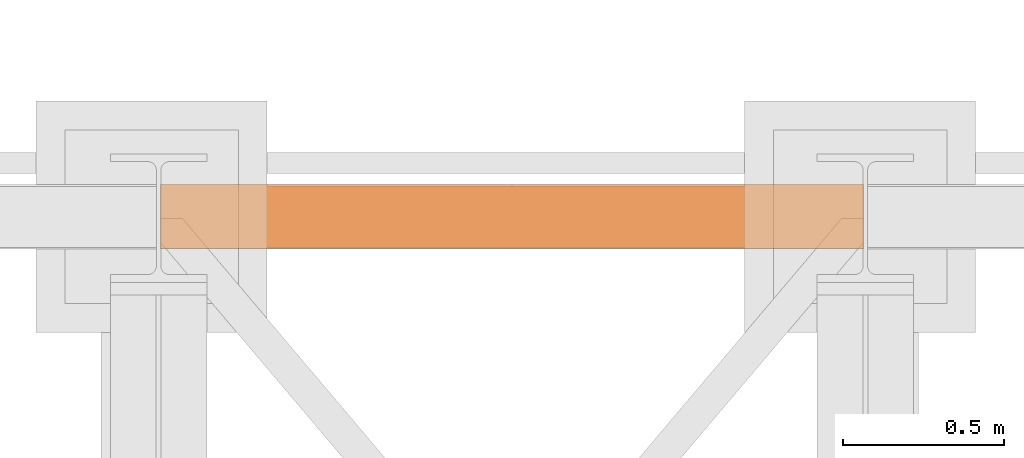
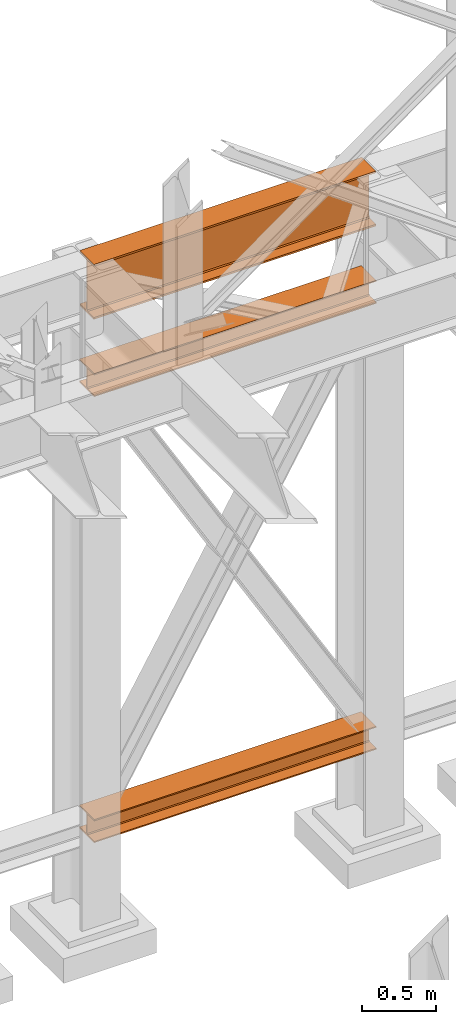
# One storey, part 139 of 208: 3 proxies.
"""IFC2X3 building model written with IfcOpenShell, lengths in millimetres."""

from ifc_helpers import new_model, entity, si_unit, converted_unit, frame, origin, origin_with_axes, place, context, subcontext, project, spatial, faceted_brep, element, save


model = new_model("IFC2X3")

# Units and contexts
model_context = context("Model", 3, precision=1e-05, world=origin())
plan_context = context("Plan", 3, precision=1e-05, world=origin())
body_context = subcontext(model_context, "Body", "Model", "MODEL_VIEW")
ifc_project = project(units=[si_unit("LENGTHUNIT", "METRE", prefix="MILLI"), converted_unit("PLANEANGLEUNIT", "DEGREE", entity("IfcPlaneAngleMeasure", 0.0174532925199433), si_unit("PLANEANGLEUNIT", "RADIAN"), dimensions=[0, 0, 0, 0, 0, 0, 0]), si_unit("AREAUNIT", "SQUARE_METRE"), si_unit("VOLUMEUNIT", "CUBIC_METRE")], contexts=[model_context, plan_context])

# Building, storey
building_placement = place(None, origin())
building = spatial("IfcBuilding", under=ifc_project, at=building_placement, CompositionType="COMPLEX")
storey_placement = place(building_placement, origin_with_axes())
storey = spatial("IfcBuildingStorey", under=building, at=storey_placement, Name="Geschoss", CompositionType="ELEMENT")

# Proxies
proxy_1_placement = place(storey_placement, frame((-0.7450314191735288, -12562.57439501763, 544.9900024165573), z_axis=(0.0, 0.0, 1.0), x_axis=(1.0, 0.0, 0.0)))
element("IfcBuildingElementProxy", 1, at=proxy_1_placement, inside=storey, context=body_context, shape_type="Brep", body=[
    faceted_brep([(2188.009999895691, 0.01000000000021828, 190.0100125169755), (2188.009999895691, 200.0100029802325, 190.0100125169755), (2188.009999895691, 200.0100029802325, 180.0100146031381), (2188.009999895691, 121.2600035762789, 180.0100071525575), (2188.009999895691, 111.9441915473344, 178.1454621052743), (2188.009999895691, 105.1245498640838, 171.3258190250398), (2188.009999895691, 103.2600015571716, 162.0100079274179), (2188.009999895691, 103.2600015571716, 28.00999713897716), (2188.009999895691, 105.1245498640838, 18.69418604135524), (2188.009999895691, 111.9441915473344, 11.87454296112071), (2188.009999895691, 121.2600035762789, 10.00999791383754), (2188.009999895691, 200.0100029802325, 10.00999791383754), (2188.009999895691, 200.0100029802325, 0.01000000000010459), (2188.009999895691, 0.01000000000021828, 0.01000000000010459), (2188.009999895691, 0.01000000000021828, 10.00999791383754), (2188.009999895691, 78.75999940395377, 10.00999791383754), (2188.009999895691, 88.07581143289826, 11.87454296112071), (2188.009999895691, 94.89545311614893, 18.69418604135524), (2188.009999895691, 96.76000142306111, 28.00999713897716), (2188.009999895691, 96.76000142306111, 162.0100079274179), (2188.009999895691, 94.89545311614893, 171.3258190250398), (2188.009999895691, 88.07581143289826, 178.1454621052743), (2188.009999895691, 78.75999940395377, 180.0100071525575), (2188.009999895691, 0.01000000000021828, 180.0100146031381), (2188.009999895691, 200.0100029802325, 190.0100125169755), (2188.009999895691, 0.01000000000021828, 190.0100125169755), (0.009999999999990905, 0.01000000000021828, 190.0100125169754), (0.009999999999990905, 200.0100029802325, 190.0100125169754), (2188.009999895691, 200.0100029802325, 180.0100146031381), (2188.009999895691, 200.0100029802325, 190.0100125169755), (0.009999999999990905, 200.0100029802325, 190.0100125169754), (0.009999999999990905, 200.0100029802325, 180.010014603138), (2188.009999895691, 121.2600035762789, 180.0100071525575), (2188.009999895691, 200.0100029802325, 180.0100146031381), (0.009999999999990905, 200.0100029802325, 180.010014603138), (0.009999999999990905, 121.2600035762789, 180.0100071525574), (2188.009999895691, 111.9441915473344, 178.1454621052743), (2188.009999895691, 121.2600035762789, 180.0100071525575), (0.009999999999990905, 121.2600035762789, 180.0100071525574), (0.009999999999990905, 111.9441915473344, 178.1454621052742), (2188.009999895691, 105.1245498640838, 171.3258190250398), (2188.009999895691, 111.9441915473344, 178.1454621052743), (0.009999999999990905, 111.9441915473344, 178.1454621052742), (0.009999999999990905, 105.1245498640838, 171.3258190250397), (2188.009999895691, 103.2600015571716, 162.0100079274179), (2188.009999895691, 105.1245498640838, 171.3258190250398), (0.009999999999990905, 105.1245498640838, 171.3258190250397), (0.009999999999990905, 103.2600015571716, 162.0100079274178), (2188.009999895691, 103.2600015571716, 28.00999713897716), (2188.009999895691, 103.2600015571716, 162.0100079274179), (0.009999999999990905, 103.2600015571716, 162.0100079274178), (0.009999999999990905, 103.2600015571716, 28.00999713897704), (2188.009999895691, 105.1245498640838, 18.69418604135524), (2188.009999895691, 103.2600015571716, 28.00999713897716), (0.009999999999990905, 103.2600015571716, 28.00999713897704), (0.009999999999990905, 105.1245498640838, 18.69418604135512), (2188.009999895691, 111.9441915473344, 11.87454296112071), (2188.009999895691, 105.1245498640838, 18.69418604135524), (0.009999999999990905, 105.1245498640838, 18.69418604135512), (0.009999999999990905, 111.9441915473344, 11.8745429611206), (2188.009999895691, 121.2600035762789, 10.00999791383754), (2188.009999895691, 111.9441915473344, 11.87454296112071), (0.009999999999990905, 111.9441915473344, 11.8745429611206), (0.009999999999990905, 121.2600035762789, 10.00999791383742), (2188.009999895691, 200.0100029802325, 10.00999791383754), (2188.009999895691, 121.2600035762789, 10.00999791383754), (0.009999999999990905, 121.2600035762789, 10.00999791383742), (0.009999999999990905, 200.0100029802325, 10.00999791383742), (2188.009999895691, 200.0100029802325, 0.01000000000010459), (2188.009999895691, 200.0100029802325, 10.00999791383754), (0.009999999999990905, 200.0100029802325, 10.00999791383742), (0.009999999999990905, 200.0100029802325, 0.009999999999990905), (2188.009999895691, 0.01000000000021828, 0.01000000000010459), (2188.009999895691, 200.0100029802325, 0.01000000000010459), (0.009999999999990905, 200.0100029802325, 0.009999999999990905), (0.009999999999990905, 0.01000000000021828, 0.009999999999990905), (2188.009999895691, 0.01000000000021828, 10.00999791383754), (2188.009999895691, 0.01000000000021828, 0.01000000000010459), (0.009999999999990905, 0.01000000000021828, 0.009999999999990905), (0.009999999999990905, 0.01000000000021828, 10.00999791383742), (2188.009999895691, 78.75999940395377, 10.00999791383754), (2188.009999895691, 0.01000000000021828, 10.00999791383754), (0.009999999999990905, 0.01000000000021828, 10.00999791383742), (0.009999999999990905, 78.75999940395377, 10.00999791383742), (2188.009999895691, 88.07581143289826, 11.87454296112071), (2188.009999895691, 78.75999940395377, 10.00999791383754), (0.009999999999990905, 78.75999940395377, 10.00999791383742), (0.009999999999990905, 88.07581143289826, 11.8745429611206), (2188.009999895691, 94.89545311614893, 18.69418604135524), (2188.009999895691, 88.07581143289826, 11.87454296112071), (0.009999999999990905, 88.07581143289826, 11.8745429611206), (0.009999999999990905, 94.89545311614893, 18.69418604135512), (2188.009999895691, 96.76000142306111, 28.00999713897716), (2188.009999895691, 94.89545311614893, 18.69418604135524), (0.009999999999990905, 94.89545311614893, 18.69418604135512), (0.009999999999990905, 96.76000142306111, 28.00999713897704), (2188.009999895691, 96.76000142306111, 162.0100079274179), (2188.009999895691, 96.76000142306111, 28.00999713897716), (0.009999999999990905, 96.76000142306111, 28.00999713897704), (0.009999999999990905, 96.76000142306111, 162.0100079274178), (2188.009999895691, 94.89545311614893, 171.3258190250398), (2188.009999895691, 96.76000142306111, 162.0100079274179), (0.009999999999990905, 96.76000142306111, 162.0100079274178), (0.009999999999990905, 94.89545311614893, 171.3258190250397), (2188.009999895691, 88.07581143289826, 178.1454621052743), (2188.009999895691, 94.89545311614893, 171.3258190250398), (0.009999999999990905, 94.89545311614893, 171.3258190250397), (0.009999999999990905, 88.07581143289826, 178.1454621052742), (2188.009999895691, 78.75999940395377, 180.0100071525575), (2188.009999895691, 88.07581143289826, 178.1454621052743), (0.009999999999990905, 88.07581143289826, 178.1454621052742), (0.009999999999990905, 78.75999940395377, 180.0100071525574), (2188.009999895691, 0.01000000000021828, 180.0100146031381), (2188.009999895691, 78.75999940395377, 180.0100071525575), (0.009999999999990905, 78.75999940395377, 180.0100071525574), (0.009999999999990905, 0.01000000000021828, 180.010014603138), (2188.009999895691, 0.01000000000021828, 190.0100125169755), (2188.009999895691, 0.01000000000021828, 180.0100146031381), (0.009999999999990905, 0.01000000000021828, 180.010014603138), (0.009999999999990905, 0.01000000000021828, 190.0100125169754), (0.009999999999990905, 0.01000000000021828, 190.0100125169754), (0.009999999999990905, 0.01000000000021828, 180.010014603138), (0.009999999999990905, 78.75999940395377, 180.0100071525574), (0.009999999999990905, 88.07581143289826, 178.1454621052742), (0.009999999999990905, 94.89545311614893, 171.3258190250397), (0.009999999999990905, 96.76000142306111, 162.0100079274178), (0.009999999999990905, 96.76000142306111, 28.00999713897704), (0.009999999999990905, 94.89545311614893, 18.69418604135512), (0.009999999999990905, 88.07581143289826, 11.8745429611206), (0.009999999999990905, 78.75999940395377, 10.00999791383742), (0.009999999999990905, 0.01000000000021828, 10.00999791383742), (0.009999999999990905, 0.01000000000021828, 0.009999999999990905), (0.009999999999990905, 200.0100029802325, 0.009999999999990905), (0.009999999999990905, 200.0100029802325, 10.00999791383742), (0.009999999999990905, 121.2600035762789, 10.00999791383742), (0.009999999999990905, 111.9441915473344, 11.8745429611206), (0.009999999999990905, 105.1245498640838, 18.69418604135512), (0.009999999999990905, 103.2600015571716, 28.00999713897704), (0.009999999999990905, 103.2600015571716, 162.0100079274178), (0.009999999999990905, 105.1245498640838, 171.3258190250397), (0.009999999999990905, 111.9441915473344, 178.1454621052742), (0.009999999999990905, 121.2600035762789, 180.0100071525574), (0.009999999999990905, 200.0100029802325, 180.010014603138), (0.009999999999990905, 200.0100029802325, 190.0100125169754)], [[[0, 1, 2, 3, 4, 5, 6, 7, 8, 9, 10, 11, 12, 13, 14, 15, 16, 17, 18, 19, 20, 21, 22, 23]], [[24, 25, 26, 27]], [[28, 29, 30, 31]], [[32, 33, 34, 35]], [[36, 37, 38, 39]], [[40, 41, 42, 43]], [[44, 45, 46, 47]], [[48, 49, 50, 51]], [[52, 53, 54, 55]], [[56, 57, 58, 59]], [[60, 61, 62, 63]], [[64, 65, 66, 67]], [[68, 69, 70, 71]], [[72, 73, 74, 75]], [[76, 77, 78, 79]], [[80, 81, 82, 83]], [[84, 85, 86, 87]], [[88, 89, 90, 91]], [[92, 93, 94, 95]], [[96, 97, 98, 99]], [[100, 101, 102, 103]], [[104, 105, 106, 107]], [[108, 109, 110, 111]], [[112, 113, 114, 115]], [[116, 117, 118, 119]], [[120, 121, 122, 123, 124, 125, 126, 127, 128, 129, 130, 131, 132, 133, 134, 135, 136, 137, 138, 139, 140, 141, 142, 143]]], orient=[[False], [False], [False], [False], [False], [False], [False], [False], [False], [False], [False], [False], [False], [False], [False], [False], [False], [False], [False], [False], [False], [False], [False], [False], [False], [False]]),
])
proxy_2_placement = place(storey_placement, frame((-0.7450314191753478, -12557.574399786, 4834.989987483023), z_axis=(0.0, 0.0, 1.0), x_axis=(1.0, 0.0, 0.0)))
element("IfcBuildingElementProxy", 2, at=proxy_2_placement, inside=storey, context=body_context, shape_type="Brep", body=[
    faceted_brep([(2188.009999895692, 0.00999999999839929, 450.0100178813937), (2188.009999895692, 190.0100125169738, 450.0100178813937), (2188.009999895692, 190.0100125169738, 435.4100240564349), (2188.009999895692, 120.7100073045476, 435.4100091552737), (2188.009999895692, 109.8415622657522, 433.2347078418734), (2188.009999895692, 101.8853126263603, 425.2784563398363), (2188.009999895692, 99.71000619068582, 414.4100113010409), (2188.009999895692, 99.71000619068582, 35.60999167919181), (2188.009999895692, 101.8853126263603, 24.74154664039634), (2188.009999895692, 109.8415622657522, 16.78529513835929), (2188.009999895692, 120.7100073045476, 14.60999382495902), (2188.009999895692, 190.0100125169738, 14.60999382495902), (2188.009999895692, 190.0100125169738, 0.01000000000021828), (2188.009999895692, 0.00999999999839929, 0.01000000000021828), (2188.009999895692, 0.00999999999839929, 14.60999382495902), (2188.009999895692, 69.31000521242458, 14.60999382495902), (2188.009999895692, 80.17845025122006, 16.78529513835929), (2188.009999895692, 88.13469989061196, 24.74154664039634), (2188.009999895692, 90.31000632628638, 35.60999167919181), (2188.009999895692, 90.31000632628638, 414.4100113010409), (2188.009999895692, 88.13469989061196, 425.2784563398363), (2188.009999895692, 80.17845025122006, 433.2347078418734), (2188.009999895692, 69.31000521242458, 435.4100091552737), (2188.009999895692, 0.00999999999839929, 435.4100240564349), (2188.009999895692, 190.0100125169738, 450.0100178813937), (2188.009999895692, 0.00999999999839929, 450.0100178813937), (0.009999999999990905, 0.01000000000021828, 450.0100178813937), (0.009999999999990905, 190.0100125169756, 450.0100178813937), (2188.009999895692, 190.0100125169738, 435.4100240564349), (2188.009999895692, 190.0100125169738, 450.0100178813937), (0.009999999999990905, 190.0100125169756, 450.0100178813937), (0.009999999999990905, 190.0100125169756, 435.4100240564349), (2188.009999895692, 120.7100073045476, 435.4100091552737), (2188.009999895692, 190.0100125169738, 435.4100240564349), (0.009999999999990905, 190.0100125169756, 435.4100240564349), (0.009999999999990905, 120.7100073045494, 435.4100091552737), (2188.009999895692, 109.8415622657522, 433.2347078418734), (2188.009999895692, 120.7100073045476, 435.4100091552737), (0.009999999999990905, 120.7100073045494, 435.4100091552737), (0.009999999999990905, 109.841562265754, 433.2347078418734), (2188.009999895692, 101.8853126263603, 425.2784563398363), (2188.009999895692, 109.8415622657522, 433.2347078418734), (0.009999999999990905, 109.841562265754, 433.2347078418734), (0.009999999999990905, 101.8853126263621, 425.2784563398363), (2188.009999895692, 99.71000619068582, 414.4100113010409), (2188.009999895692, 101.8853126263603, 425.2784563398363), (0.009999999999990905, 101.8853126263621, 425.2784563398363), (0.009999999999990905, 99.71000619068764, 414.4100113010409), (2188.009999895692, 99.71000619068582, 35.60999167919181), (2188.009999895692, 99.71000619068582, 414.4100113010409), (0.009999999999990905, 99.71000619068764, 414.4100113010409), (0.009999999999990905, 99.71000619068764, 35.60999167919181), (2188.009999895692, 101.8853126263603, 24.74154664039634), (2188.009999895692, 99.71000619068582, 35.60999167919181), (0.009999999999990905, 99.71000619068764, 35.60999167919181), (0.009999999999990905, 101.8853126263621, 24.74154664039634), (2188.009999895692, 109.8415622657522, 16.78529513835929), (2188.009999895692, 101.8853126263603, 24.74154664039634), (0.009999999999990905, 101.8853126263621, 24.74154664039634), (0.009999999999990905, 109.841562265754, 16.78529513835929), (2188.009999895692, 120.7100073045476, 14.60999382495902), (2188.009999895692, 109.8415622657522, 16.78529513835929), (0.009999999999990905, 109.841562265754, 16.78529513835929), (0.009999999999990905, 120.7100073045494, 14.60999382495902), (2188.009999895692, 190.0100125169738, 14.60999382495902), (2188.009999895692, 120.7100073045476, 14.60999382495902), (0.009999999999990905, 120.7100073045494, 14.60999382495902), (0.009999999999990905, 190.0100125169756, 14.60999382495902), (2188.009999895692, 190.0100125169738, 0.01000000000021828), (2188.009999895692, 190.0100125169738, 14.60999382495902), (0.009999999999990905, 190.0100125169756, 14.60999382495902), (0.009999999999990905, 190.0100125169756, 0.01000000000021828), (2188.009999895692, 0.00999999999839929, 0.01000000000021828), (2188.009999895692, 190.0100125169738, 0.01000000000021828), (0.009999999999990905, 190.0100125169756, 0.01000000000021828), (0.009999999999990905, 0.01000000000021828, 0.01000000000021828), (2188.009999895692, 0.00999999999839929, 14.60999382495902), (2188.009999895692, 0.00999999999839929, 0.01000000000021828), (0.009999999999990905, 0.01000000000021828, 0.01000000000021828), (0.009999999999990905, 0.01000000000021828, 14.60999382495902), (2188.009999895692, 69.31000521242458, 14.60999382495902), (2188.009999895692, 0.00999999999839929, 14.60999382495902), (0.009999999999990905, 0.01000000000021828, 14.60999382495902), (0.009999999999990905, 69.3100052124264, 14.60999382495902), (2188.009999895692, 80.17845025122006, 16.78529513835929), (2188.009999895692, 69.31000521242458, 14.60999382495902), (0.009999999999990905, 69.3100052124264, 14.60999382495902), (0.009999999999990905, 80.17845025122188, 16.78529513835929), (2188.009999895692, 88.13469989061196, 24.74154664039634), (2188.009999895692, 80.17845025122006, 16.78529513835929), (0.009999999999990905, 80.17845025122188, 16.78529513835929), (0.009999999999990905, 88.13469989061377, 24.74154664039634), (2188.009999895692, 90.31000632628638, 35.60999167919181), (2188.009999895692, 88.13469989061196, 24.74154664039634), (0.009999999999990905, 88.13469989061377, 24.74154664039634), (0.009999999999990905, 90.3100063262882, 35.60999167919181), (2188.009999895692, 90.31000632628638, 414.4100113010409), (2188.009999895692, 90.31000632628638, 35.60999167919181), (0.009999999999990905, 90.3100063262882, 35.60999167919181), (0.009999999999990905, 90.3100063262882, 414.4100113010409), (2188.009999895692, 88.13469989061196, 425.2784563398363), (2188.009999895692, 90.31000632628638, 414.4100113010409), (0.009999999999990905, 90.3100063262882, 414.4100113010409), (0.009999999999990905, 88.13469989061377, 425.2784563398363), (2188.009999895692, 80.17845025122006, 433.2347078418734), (2188.009999895692, 88.13469989061196, 425.2784563398363), (0.009999999999990905, 88.13469989061377, 425.2784563398363), (0.009999999999990905, 80.17845025122188, 433.2347078418734), (2188.009999895692, 69.31000521242458, 435.4100091552737), (2188.009999895692, 80.17845025122006, 433.2347078418734), (0.009999999999990905, 80.17845025122188, 433.2347078418734), (0.009999999999990905, 69.3100052124264, 435.4100091552737), (2188.009999895692, 0.00999999999839929, 435.4100240564349), (2188.009999895692, 69.31000521242458, 435.4100091552737), (0.009999999999990905, 69.3100052124264, 435.4100091552737), (0.009999999999990905, 0.01000000000021828, 435.4100240564349), (2188.009999895692, 0.00999999999839929, 450.0100178813937), (2188.009999895692, 0.00999999999839929, 435.4100240564349), (0.009999999999990905, 0.01000000000021828, 435.4100240564349), (0.009999999999990905, 0.01000000000021828, 450.0100178813937), (0.009999999999990905, 0.01000000000021828, 450.0100178813937), (0.009999999999990905, 0.01000000000021828, 435.4100240564349), (0.009999999999990905, 69.3100052124264, 435.4100091552737), (0.009999999999990905, 80.17845025122188, 433.2347078418734), (0.009999999999990905, 88.13469989061377, 425.2784563398363), (0.009999999999990905, 90.3100063262882, 414.4100113010409), (0.009999999999990905, 90.3100063262882, 35.60999167919181), (0.009999999999990905, 88.13469989061377, 24.74154664039634), (0.009999999999990905, 80.17845025122188, 16.78529513835929), (0.009999999999990905, 69.3100052124264, 14.60999382495902), (0.009999999999990905, 0.01000000000021828, 14.60999382495902), (0.009999999999990905, 0.01000000000021828, 0.01000000000021828), (0.009999999999990905, 190.0100125169756, 0.01000000000021828), (0.009999999999990905, 190.0100125169756, 14.60999382495902), (0.009999999999990905, 120.7100073045494, 14.60999382495902), (0.009999999999990905, 109.841562265754, 16.78529513835929), (0.009999999999990905, 101.8853126263621, 24.74154664039634), (0.009999999999990905, 99.71000619068764, 35.60999167919181), (0.009999999999990905, 99.71000619068764, 414.4100113010409), (0.009999999999990905, 101.8853126263621, 425.2784563398363), (0.009999999999990905, 109.841562265754, 433.2347078418734), (0.009999999999990905, 120.7100073045494, 435.4100091552737), (0.009999999999990905, 190.0100125169756, 435.4100240564349), (0.009999999999990905, 190.0100125169756, 450.0100178813937)], [[[0, 1, 2, 3, 4, 5, 6, 7, 8, 9, 10, 11, 12, 13, 14, 15, 16, 17, 18, 19, 20, 21, 22, 23]], [[24, 25, 26, 27]], [[28, 29, 30, 31]], [[32, 33, 34, 35]], [[36, 37, 38, 39]], [[40, 41, 42, 43]], [[44, 45, 46, 47]], [[48, 49, 50, 51]], [[52, 53, 54, 55]], [[56, 57, 58, 59]], [[60, 61, 62, 63]], [[64, 65, 66, 67]], [[68, 69, 70, 71]], [[72, 73, 74, 75]], [[76, 77, 78, 79]], [[80, 81, 82, 83]], [[84, 85, 86, 87]], [[88, 89, 90, 91]], [[92, 93, 94, 95]], [[96, 97, 98, 99]], [[100, 101, 102, 103]], [[104, 105, 106, 107]], [[108, 109, 110, 111]], [[112, 113, 114, 115]], [[116, 117, 118, 119]], [[120, 121, 122, 123, 124, 125, 126, 127, 128, 129, 130, 131, 132, 133, 134, 135, 136, 137, 138, 139, 140, 141, 142, 143]]], orient=[[False], [False], [False], [False], [False], [False], [False], [False], [False], [False], [False], [False], [False], [False], [False], [False], [False], [False], [False], [False], [False], [False], [False], [False], [False], [False]]),
])
proxy_3_placement = place(storey_placement, frame((-0.7450314191735288, -12562.57439501764, 4202.989992847441), z_axis=(0.0, 0.0, 1.0), x_axis=(1.0, 0.0, 0.0)))
element("IfcBuildingElementProxy", 3, at=proxy_3_placement, inside=storey, context=body_context, shape_type="Brep", body=[
    faceted_brep([(2188.00999989569, 0.01000000000021828, 190.0100125169756), (2188.00999989569, 200.0100029802325, 190.0100125169756), (2188.00999989569, 200.0100029802325, 180.0100146031382), (2188.00999989569, 121.2600035762789, 180.0100071525576), (2188.00999989569, 111.9441915473344, 178.1454621052744), (2188.00999989569, 105.1245498640838, 171.3258190250399), (2188.00999989569, 103.2600015571716, 162.010007927418), (2188.00999989569, 103.2600015571716, 28.00999713897727), (2188.00999989569, 105.1245498640838, 18.69418604135535), (2188.00999989569, 111.9441915473344, 11.87454296112082), (2188.00999989569, 121.2600035762789, 10.00999791383765), (2188.00999989569, 200.0100029802325, 10.00999791383765), (2188.00999989569, 200.0100029802325, 0.01000000000021828), (2188.00999989569, 0.01000000000021828, 0.01000000000021828), (2188.00999989569, 0.01000000000021828, 10.00999791383765), (2188.00999989569, 78.75999940395377, 10.00999791383765), (2188.00999989569, 88.07581143289826, 11.87454296112082), (2188.00999989569, 94.89545311614893, 18.69418604135535), (2188.00999989569, 96.76000142306111, 28.00999713897727), (2188.00999989569, 96.76000142306111, 162.010007927418), (2188.00999989569, 94.89545311614893, 171.3258190250399), (2188.00999989569, 88.07581143289826, 178.1454621052744), (2188.00999989569, 78.75999940395377, 180.0100071525576), (2188.00999989569, 0.01000000000021828, 180.0100146031382), (2188.00999989569, 200.0100029802325, 190.0100125169756), (2188.00999989569, 0.01000000000021828, 190.0100125169756), (0.009999999999990905, 0.01000000000021828, 190.0100125169756), (0.009999999999990905, 200.0100029802325, 190.0100125169756), (2188.00999989569, 200.0100029802325, 180.0100146031382), (2188.00999989569, 200.0100029802325, 190.0100125169756), (0.009999999999990905, 200.0100029802325, 190.0100125169756), (0.009999999999990905, 200.0100029802325, 180.0100146031382), (2188.00999989569, 121.2600035762789, 180.0100071525576), (2188.00999989569, 200.0100029802325, 180.0100146031382), (0.009999999999990905, 200.0100029802325, 180.0100146031382), (0.009999999999990905, 121.2600035762789, 180.0100071525576), (2188.00999989569, 111.9441915473344, 178.1454621052744), (2188.00999989569, 121.2600035762789, 180.0100071525576), (0.009999999999990905, 121.2600035762789, 180.0100071525576), (0.009999999999990905, 111.9441915473344, 178.1454621052744), (2188.00999989569, 105.1245498640838, 171.3258190250399), (2188.00999989569, 111.9441915473344, 178.1454621052744), (0.009999999999990905, 111.9441915473344, 178.1454621052744), (0.009999999999990905, 105.1245498640838, 171.3258190250399), (2188.00999989569, 103.2600015571716, 162.010007927418), (2188.00999989569, 105.1245498640838, 171.3258190250399), (0.009999999999990905, 105.1245498640838, 171.3258190250399), (0.009999999999990905, 103.2600015571716, 162.010007927418), (2188.00999989569, 103.2600015571716, 28.00999713897727), (2188.00999989569, 103.2600015571716, 162.010007927418), (0.009999999999990905, 103.2600015571716, 162.010007927418), (0.009999999999990905, 103.2600015571716, 28.00999713897727), (2188.00999989569, 105.1245498640838, 18.69418604135535), (2188.00999989569, 103.2600015571716, 28.00999713897727), (0.009999999999990905, 103.2600015571716, 28.00999713897727), (0.009999999999990905, 105.1245498640838, 18.69418604135535), (2188.00999989569, 111.9441915473344, 11.87454296112082), (2188.00999989569, 105.1245498640838, 18.69418604135535), (0.009999999999990905, 105.1245498640838, 18.69418604135535), (0.009999999999990905, 111.9441915473344, 11.87454296112082), (2188.00999989569, 121.2600035762789, 10.00999791383765), (2188.00999989569, 111.9441915473344, 11.87454296112082), (0.009999999999990905, 111.9441915473344, 11.87454296112082), (0.009999999999990905, 121.2600035762789, 10.00999791383765), (2188.00999989569, 200.0100029802325, 10.00999791383765), (2188.00999989569, 121.2600035762789, 10.00999791383765), (0.009999999999990905, 121.2600035762789, 10.00999791383765), (0.009999999999990905, 200.0100029802325, 10.00999791383765), (2188.00999989569, 200.0100029802325, 0.01000000000021828), (2188.00999989569, 200.0100029802325, 10.00999791383765), (0.009999999999990905, 200.0100029802325, 10.00999791383765), (0.009999999999990905, 200.0100029802325, 0.01000000000021828), (2188.00999989569, 0.01000000000021828, 0.01000000000021828), (2188.00999989569, 200.0100029802325, 0.01000000000021828), (0.009999999999990905, 200.0100029802325, 0.01000000000021828), (0.009999999999990905, 0.01000000000021828, 0.01000000000021828), (2188.00999989569, 0.01000000000021828, 10.00999791383765), (2188.00999989569, 0.01000000000021828, 0.01000000000021828), (0.009999999999990905, 0.01000000000021828, 0.01000000000021828), (0.009999999999990905, 0.01000000000021828, 10.00999791383765), (2188.00999989569, 78.75999940395377, 10.00999791383765), (2188.00999989569, 0.01000000000021828, 10.00999791383765), (0.009999999999990905, 0.01000000000021828, 10.00999791383765), (0.009999999999990905, 78.75999940395377, 10.00999791383765), (2188.00999989569, 88.07581143289826, 11.87454296112082), (2188.00999989569, 78.75999940395377, 10.00999791383765), (0.009999999999990905, 78.75999940395377, 10.00999791383765), (0.009999999999990905, 88.07581143289826, 11.87454296112082), (2188.00999989569, 94.89545311614893, 18.69418604135535), (2188.00999989569, 88.07581143289826, 11.87454296112082), (0.009999999999990905, 88.07581143289826, 11.87454296112082), (0.009999999999990905, 94.89545311614893, 18.69418604135535), (2188.00999989569, 96.76000142306111, 28.00999713897727), (2188.00999989569, 94.89545311614893, 18.69418604135535), (0.009999999999990905, 94.89545311614893, 18.69418604135535), (0.009999999999990905, 96.76000142306111, 28.00999713897727), (2188.00999989569, 96.76000142306111, 162.010007927418), (2188.00999989569, 96.76000142306111, 28.00999713897727), (0.009999999999990905, 96.76000142306111, 28.00999713897727), (0.009999999999990905, 96.76000142306111, 162.010007927418), (2188.00999989569, 94.89545311614893, 171.3258190250399), (2188.00999989569, 96.76000142306111, 162.010007927418), (0.009999999999990905, 96.76000142306111, 162.010007927418), (0.009999999999990905, 94.89545311614893, 171.3258190250399), (2188.00999989569, 88.07581143289826, 178.1454621052744), (2188.00999989569, 94.89545311614893, 171.3258190250399), (0.009999999999990905, 94.89545311614893, 171.3258190250399), (0.009999999999990905, 88.07581143289826, 178.1454621052744), (2188.00999989569, 78.75999940395377, 180.0100071525576), (2188.00999989569, 88.07581143289826, 178.1454621052744), (0.009999999999990905, 88.07581143289826, 178.1454621052744), (0.009999999999990905, 78.75999940395377, 180.0100071525576), (2188.00999989569, 0.01000000000021828, 180.0100146031382), (2188.00999989569, 78.75999940395377, 180.0100071525576), (0.009999999999990905, 78.75999940395377, 180.0100071525576), (0.009999999999990905, 0.01000000000021828, 180.0100146031382), (2188.00999989569, 0.01000000000021828, 190.0100125169756), (2188.00999989569, 0.01000000000021828, 180.0100146031382), (0.009999999999990905, 0.01000000000021828, 180.0100146031382), (0.009999999999990905, 0.01000000000021828, 190.0100125169756), (0.009999999999990905, 0.01000000000021828, 190.0100125169756), (0.009999999999990905, 0.01000000000021828, 180.0100146031382), (0.009999999999990905, 78.75999940395377, 180.0100071525576), (0.009999999999990905, 88.07581143289826, 178.1454621052744), (0.009999999999990905, 94.89545311614893, 171.3258190250399), (0.009999999999990905, 96.76000142306111, 162.010007927418), (0.009999999999990905, 96.76000142306111, 28.00999713897727), (0.009999999999990905, 94.89545311614893, 18.69418604135535), (0.009999999999990905, 88.07581143289826, 11.87454296112082), (0.009999999999990905, 78.75999940395377, 10.00999791383765), (0.009999999999990905, 0.01000000000021828, 10.00999791383765), (0.009999999999990905, 0.01000000000021828, 0.01000000000021828), (0.009999999999990905, 200.0100029802325, 0.01000000000021828), (0.009999999999990905, 200.0100029802325, 10.00999791383765), (0.009999999999990905, 121.2600035762789, 10.00999791383765), (0.009999999999990905, 111.9441915473344, 11.87454296112082), (0.009999999999990905, 105.1245498640838, 18.69418604135535), (0.009999999999990905, 103.2600015571716, 28.00999713897727), (0.009999999999990905, 103.2600015571716, 162.010007927418), (0.009999999999990905, 105.1245498640838, 171.3258190250399), (0.009999999999990905, 111.9441915473344, 178.1454621052744), (0.009999999999990905, 121.2600035762789, 180.0100071525576), (0.009999999999990905, 200.0100029802325, 180.0100146031382), (0.009999999999990905, 200.0100029802325, 190.0100125169756)], [[[0, 1, 2, 3, 4, 5, 6, 7, 8, 9, 10, 11, 12, 13, 14, 15, 16, 17, 18, 19, 20, 21, 22, 23]], [[24, 25, 26, 27]], [[28, 29, 30, 31]], [[32, 33, 34, 35]], [[36, 37, 38, 39]], [[40, 41, 42, 43]], [[44, 45, 46, 47]], [[48, 49, 50, 51]], [[52, 53, 54, 55]], [[56, 57, 58, 59]], [[60, 61, 62, 63]], [[64, 65, 66, 67]], [[68, 69, 70, 71]], [[72, 73, 74, 75]], [[76, 77, 78, 79]], [[80, 81, 82, 83]], [[84, 85, 86, 87]], [[88, 89, 90, 91]], [[92, 93, 94, 95]], [[96, 97, 98, 99]], [[100, 101, 102, 103]], [[104, 105, 106, 107]], [[108, 109, 110, 111]], [[112, 113, 114, 115]], [[116, 117, 118, 119]], [[120, 121, 122, 123, 124, 125, 126, 127, 128, 129, 130, 131, 132, 133, 134, 135, 136, 137, 138, 139, 140, 141, 142, 143]]], orient=[[False], [False], [False], [False], [False], [False], [False], [False], [False], [False], [False], [False], [False], [False], [False], [False], [False], [False], [False], [False], [False], [False], [False], [False], [False], [False]]),
])

save(model, "model.ifc")
